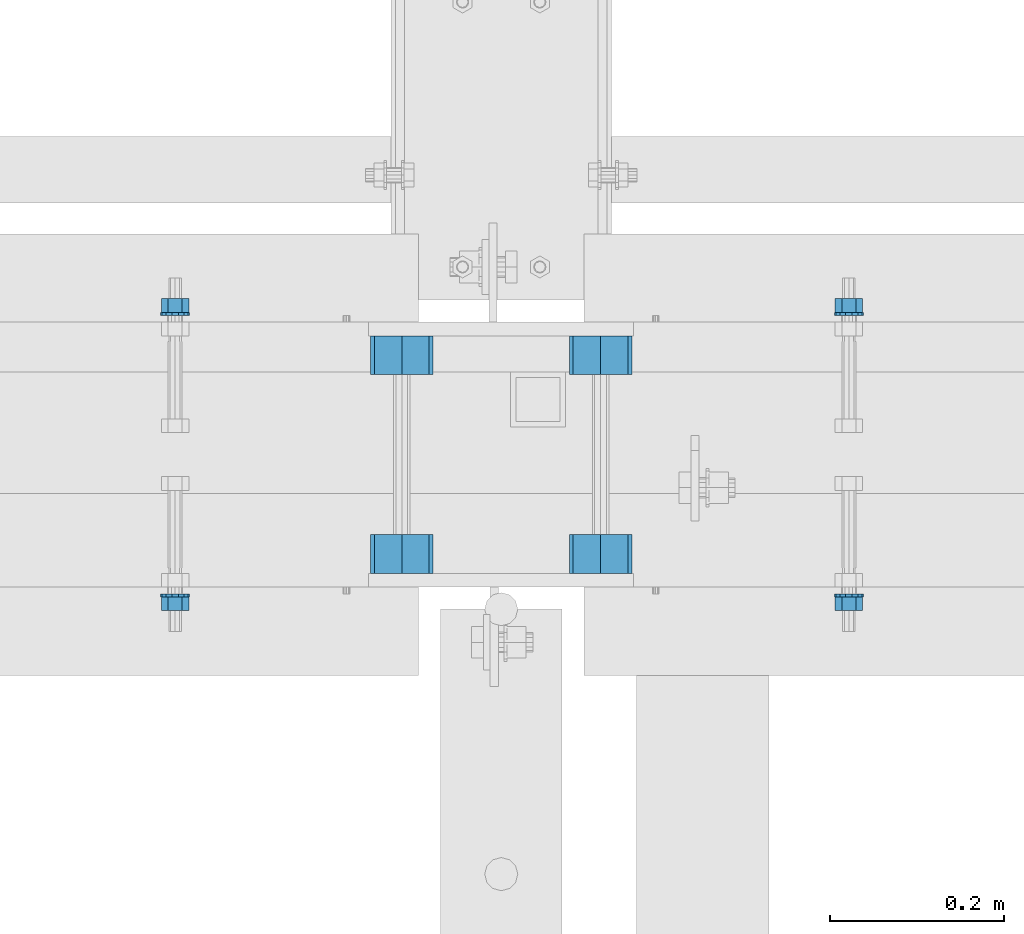
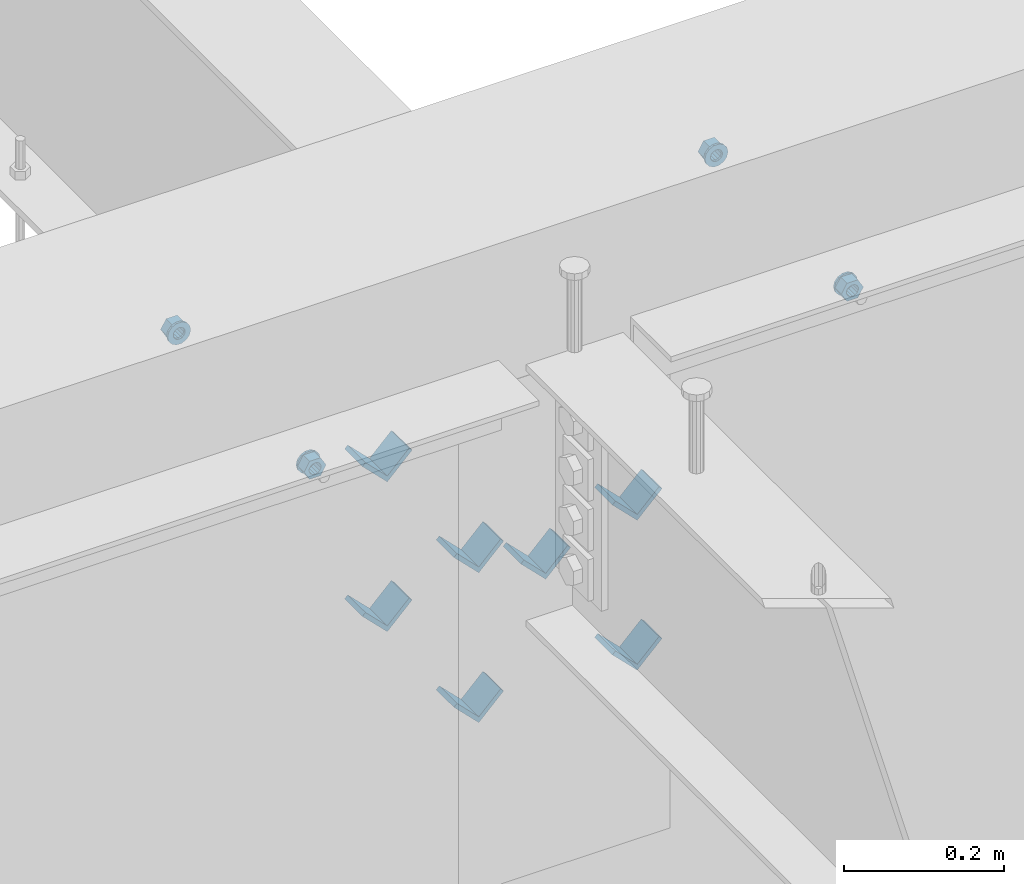
# One storey, part 609 of 975: 15 beams.
"""IFC2X3 building model written with IfcOpenShell, lengths in millimetres."""

from ifc_helpers import new_model, si_unit, frame, origin_with_axes, place, context, subcontext, project, spatial, faceted_brep, material, type_object, element, save


model = new_model("IFC2X3")

# Units and contexts
model_context = context("Model", 3, precision=1e-05, world=origin_with_axes())
body_context = subcontext(model_context, "Body", "Model", "MODEL_VIEW")
ifc_project = project(units=[si_unit("LENGTHUNIT", "METRE", prefix="MILLI"), si_unit("AREAUNIT", "SQUARE_METRE"), si_unit("VOLUMEUNIT", "CUBIC_METRE"), si_unit("MASSUNIT", "GRAM", prefix="KILO"), si_unit("TIMEUNIT", "SECOND"), si_unit("PLANEANGLEUNIT", "RADIAN"), si_unit("SOLIDANGLEUNIT", "STERADIAN"), si_unit("THERMODYNAMICTEMPERATUREUNIT", "DEGREE_CELSIUS"), si_unit("LUMINOUSINTENSITYUNIT", "LUMEN")], contexts=[model_context])

# Site, building, storey
site_placement = place(None, origin_with_axes())
site = spatial("IfcSite", under=ifc_project, at=site_placement, CompositionType="ELEMENT")
building_placement = place(site_placement, origin_with_axes())
building = spatial("IfcBuilding", under=site, at=building_placement, Name="Undefined", CompositionType="ELEMENT")
storey_placement = place(building_placement, origin_with_axes())
storey = spatial("IfcBuildingStorey", under=building, at=storey_placement, Name="Undefined", CompositionType="ELEMENT", Elevation=0.0)

# Beams
ifc_material = material(Name="STEEL/A36")
beam_type_1 = type_object("IfcBeamType", Name="L2X2X1/4", PredefinedType="NOTDEFINED")
for number, where, z_axis, x_axis, name in (
    (1, (8115.30041900943, 20459.6337290899, 3417.06996517217), (-0.707106781186557, 0.0, 0.707106781186538), (0.0, 1.0, 0.0), "ANGLE"),
    (2, (8343.90041900943, 20459.6337290899, 3417.06996517217), (-0.707106781186557, 0.0, 0.707106781186538), (0.0, 1.0, 0.0), "ANGLE"),
    (3, (8115.30041900943, 20688.3662709101, 3417.06996517217), (-0.707106781186557, 0.0, 0.707106781186538), (0.0, 1.0, 0.0), "ANGLE"),
    (4, (8343.90041900943, 20688.3662709101, 3417.06996517217), (-0.707106781186557, 0.0, 0.707106781186538), (0.0, 1.0, 0.0), "ANGLE"),
    (5, (8115.30041900943, 20459.6337290899, 3645.66996517217), (-0.707106781186557, 0.0, 0.707106781186538), (0.0, 1.0, 0.0), "ANGLE"),
    (6, (8343.90041900943, 20459.6337290899, 3645.66996517217), (-0.707106781186557, 0.0, 0.707106781186538), (0.0, 1.0, 0.0), "ANGLE"),
    (7, (8115.30041900943, 20688.3662709101, 3645.66996517217), (-0.707106781186557, 0.0, 0.707106781186538), (0.0, 1.0, 0.0), "ANGLE"),
):
    element("IfcBeam", number, at=place(storey_placement, frame(where, z_axis=z_axis, x_axis=x_axis)), inside=storey, type_object=beam_type_1, material=ifc_material, Name=name, ObjectType="L2X2X1/4", context=body_context, shape_type="Brep", body=[
        faceted_brep([(0.0, 25.3999999999724, -25.4000000000342), (0.0, 25.400000000016, 25.4000000000196), (44.4499999999971, 25.4000000000033, 25.4000000000051), (44.4499999999971, 25.4000000000033, -25.4000000000024), (3.27418092638254e-11, 19.0500000000002, 25.4000000000269), (44.4499999999971, 19.0500000000011, 25.400000000006), (-2.5465851649642e-11, 19.0500000000002, -19.0500000000211), (44.4499999999971, 19.0500000000011, -19.050000000002), (-2.5465851649642e-11, -25.3999999999996, -19.0500000000211), (44.4499999999971, -25.4000000000069, -19.0500000000038), (0.0, -25.400000000016, -25.4000000000196), (44.4499999999971, -25.4000000000069, -25.4000000000033)], [[[0, 1, 2, 3]], [[1, 4, 5, 2]], [[4, 6, 7, 5]], [[6, 8, 9, 7]], [[8, 10, 11, 9]], [[10, 0, 3, 11]], [[5, 7, 9, 11, 3, 2]], [[10, 8, 6, 4, 1, 0]]]),
    ])
beam_type_2 = type_object("IfcBeamType", Name="5/8_HEAVY_HEX_NUT", PredefinedType="NOTDEFINED")
beam_1_placement = place(storey_placement, frame((7854.4208401876, 20775.6125, 3886.2), z_axis=(0.0, 0.0, -1.0), x_axis=(0.0, -1.0, 0.0)))
element("IfcBeam", 8, at=beam_1_placement, inside=storey, type_object=beam_type_2, material=ifc_material, Name="NUT", ObjectType="5/8_HEAVY_HEX_NUT", context=body_context, shape_type="Brep", body=[
    faceted_brep([(-1.09139364212751e-11, -15.8800001144436, -2.72848410531878e-12), (1.45519152283669e-11, -7.94000005722046, -13.7500000000036), (15.8750000000146, -7.94000005722137, -13.7500000000045), (15.8749999999891, -15.8800001144446, -2.72848410531878e-12), (2.91038304567337e-11, 7.94000005722319, -13.7500000000027), (15.8750000000291, 7.94000005722319, -13.7500000000027), (2.18278728425503e-11, 15.8800001144436, 9.09494701772928e-13), (15.8750000000218, 15.8800001144427, 9.09494701772928e-13), (-7.27595761418343e-12, 7.94000005722046, 13.7500000000027), (15.8749999999927, 7.94000005722046, 13.7500000000027), (-2.18278728425503e-11, -7.94000005722228, 13.7500000000009), (15.8749999999782, -7.94000005722319, 13.7500000000009), (-7.27595761418343e-12, 0.0, 8.72999954223724), (0.0, 3.78780484388062, 7.86545780435881), (15.875, 3.78780484387971, 7.86545780435881), (15.8749999999927, -9.09494701772928e-13, 8.72999954223724), (7.27595761418343e-12, 6.82538848405238, 5.44306568481716), (15.8750000000073, 6.82538848405238, 5.44306568481716), (1.09139364212751e-11, 8.51112022706275, 1.94260765157742), (15.8750000000109, 8.51112022706093, 1.94260765157651), (1.45519152283669e-11, 8.51112022706184, -1.94260765157651), (15.8750000000146, 8.51112022706184, -1.94260765157651), (2.18278728425503e-11, 6.8253884840542, -5.44306568481716), (15.8750000000218, 6.82538848405238, -5.44306568481716), (1.81898940354586e-11, 3.78780484388153, -7.86545780435881), (15.8750000000182, 3.78780484388062, -7.86545780435881), (1.81898940354586e-11, 9.09494701772928e-13, -8.72999954223997), (15.8750000000182, 9.09494701772928e-13, -8.72999954223997), (1.09139364212751e-11, -3.78780484387971, -7.86545780436063), (15.8750000000109, -3.78780484388062, -7.86545780436063), (3.63797880709171e-12, -6.82538848405238, -5.44306568481807), (15.8750000000036, -6.82538848405329, -5.44306568481807), (0.0, -8.51112022706184, -1.94260765157833), (15.875, -8.51112022706184, -1.94260765157833), (-7.27595761418343e-12, -8.51112022706184, 1.9426076515756), (15.8749999999927, -8.51112022706275, 1.9426076515756), (-1.09139364212751e-11, -6.82538848405329, 5.44306568481534), (15.8749999999927, -6.8253884840542, 5.44306568481534), (-7.27595761418343e-12, -3.78780484388062, 7.8654578043579), (15.8749999999927, -3.78780484388153, 7.8654578043579)], [[[0, 1, 2, 3]], [[1, 4, 5, 2]], [[4, 6, 7, 5]], [[6, 8, 9, 7]], [[8, 10, 11, 9]], [[10, 0, 3, 11]], [[12, 13, 14, 15]], [[13, 16, 17, 14]], [[16, 18, 19, 17]], [[18, 20, 21, 19]], [[20, 22, 23, 21]], [[22, 24, 25, 23]], [[24, 26, 27, 25]], [[26, 28, 29, 27]], [[28, 30, 31, 29]], [[30, 32, 33, 31]], [[32, 34, 35, 33]], [[34, 36, 37, 35]], [[36, 38, 39, 37]], [[38, 12, 15, 39]], [[5, 7, 9, 11, 3, 2], [17, 19, 21, 23, 25, 27, 29, 31, 33, 35, 37, 39, 15, 14]], [[10, 8, 6, 4, 1, 0], [38, 36, 34, 32, 30, 28, 26, 24, 22, 20, 18, 16, 13, 12]]]),
])
beam_2_placement = place(storey_placement, frame((8629.6499755824, 20775.6125, 3886.2), z_axis=(0.0, 0.0, 1.0), x_axis=(0.0, -1.0, 0.0)))
element("IfcBeam", 9, at=beam_2_placement, inside=storey, type_object=beam_type_2, material=ifc_material, Name="NUT", ObjectType="5/8_HEAVY_HEX_NUT", context=body_context, shape_type="Brep", body=[
    faceted_brep([(-1.09139364212751e-11, -15.8800001144436, -2.72848410531878e-12), (1.45519152283669e-11, -7.94000005722046, -13.7500000000036), (15.8750000000146, -7.94000005722137, -13.7500000000045), (15.8749999999891, -15.8800001144446, -2.72848410531878e-12), (2.91038304567337e-11, 7.94000005722319, -13.7500000000027), (15.8750000000291, 7.94000005722319, -13.7500000000027), (2.18278728425503e-11, 15.8800001144436, 9.09494701772928e-13), (15.8750000000218, 15.8800001144427, 9.09494701772928e-13), (-7.27595761418343e-12, 7.94000005722046, 13.7500000000027), (15.8749999999927, 7.94000005722046, 13.7500000000027), (-2.18278728425503e-11, -7.94000005722228, 13.7500000000009), (15.8749999999782, -7.94000005722319, 13.7500000000009), (-7.27595761418343e-12, 0.0, 8.72999954223724), (0.0, 3.78780484388062, 7.86545780435881), (15.875, 3.78780484387971, 7.86545780435881), (15.8749999999927, -9.09494701772928e-13, 8.72999954223724), (7.27595761418343e-12, 6.82538848405238, 5.44306568481716), (15.8750000000073, 6.82538848405238, 5.44306568481716), (1.09139364212751e-11, 8.51112022706275, 1.94260765157742), (15.8750000000109, 8.51112022706093, 1.94260765157651), (1.45519152283669e-11, 8.51112022706184, -1.94260765157651), (15.8750000000146, 8.51112022706184, -1.94260765157651), (2.18278728425503e-11, 6.8253884840542, -5.44306568481716), (15.8750000000218, 6.82538848405238, -5.44306568481716), (1.81898940354586e-11, 3.78780484388153, -7.86545780435881), (15.8750000000182, 3.78780484388062, -7.86545780435881), (1.81898940354586e-11, 9.09494701772928e-13, -8.72999954223997), (15.8750000000182, 9.09494701772928e-13, -8.72999954223997), (1.09139364212751e-11, -3.78780484387971, -7.86545780436063), (15.8750000000109, -3.78780484388062, -7.86545780436063), (3.63797880709171e-12, -6.82538848405238, -5.44306568481807), (15.8750000000036, -6.82538848405329, -5.44306568481807), (0.0, -8.51112022706184, -1.94260765157833), (15.875, -8.51112022706184, -1.94260765157833), (-7.27595761418343e-12, -8.51112022706184, 1.9426076515756), (15.8749999999927, -8.51112022706275, 1.9426076515756), (-1.09139364212751e-11, -6.82538848405329, 5.44306568481534), (15.8749999999927, -6.8253884840542, 5.44306568481534), (-7.27595761418343e-12, -3.78780484388062, 7.8654578043579), (15.8749999999927, -3.78780484388153, 7.8654578043579)], [[[0, 1, 2, 3]], [[1, 4, 5, 2]], [[4, 6, 7, 5]], [[6, 8, 9, 7]], [[8, 10, 11, 9]], [[10, 0, 3, 11]], [[12, 13, 14, 15]], [[13, 16, 17, 14]], [[16, 18, 19, 17]], [[18, 20, 21, 19]], [[20, 22, 23, 21]], [[22, 24, 25, 23]], [[24, 26, 27, 25]], [[26, 28, 29, 27]], [[28, 30, 31, 29]], [[30, 32, 33, 31]], [[32, 34, 35, 33]], [[34, 36, 37, 35]], [[36, 38, 39, 37]], [[38, 12, 15, 39]], [[5, 7, 9, 11, 3, 2], [17, 19, 21, 23, 25, 27, 29, 31, 33, 35, 37, 39, 15, 14]], [[10, 8, 6, 4, 1, 0], [38, 36, 34, 32, 30, 28, 26, 24, 22, 20, 18, 16, 13, 12]]]),
])
beam_3_placement = place(storey_placement, frame((7854.4208401876, 20416.8375, 3886.2), z_axis=(0.0, 0.0, 1.0), x_axis=(0.0, 1.0, 0.0)))
element("IfcBeam", 10, at=beam_3_placement, inside=storey, type_object=beam_type_2, material=ifc_material, Name="NUT", ObjectType="5/8_HEAVY_HEX_NUT", context=body_context, shape_type="Brep", body=[
    faceted_brep([(-1.09139364212751e-11, -15.8800001144436, -2.72848410531878e-12), (1.45519152283669e-11, -7.94000005722046, -13.7500000000036), (15.8750000000146, -7.94000005722137, -13.7500000000045), (15.8749999999891, -15.8800001144446, -2.72848410531878e-12), (2.91038304567337e-11, 7.94000005722319, -13.7500000000027), (15.8750000000291, 7.94000005722319, -13.7500000000027), (2.18278728425503e-11, 15.8800001144436, 9.09494701772928e-13), (15.8750000000218, 15.8800001144427, 9.09494701772928e-13), (-7.27595761418343e-12, 7.94000005722046, 13.7500000000027), (15.8749999999927, 7.94000005722046, 13.7500000000027), (-2.18278728425503e-11, -7.94000005722228, 13.7500000000009), (15.8749999999782, -7.94000005722319, 13.7500000000009), (-7.27595761418343e-12, 0.0, 8.72999954223724), (0.0, 3.78780484388062, 7.86545780435881), (15.875, 3.78780484387971, 7.86545780435881), (15.8749999999927, -9.09494701772928e-13, 8.72999954223724), (7.27595761418343e-12, 6.82538848405238, 5.44306568481716), (15.8750000000073, 6.82538848405238, 5.44306568481716), (1.09139364212751e-11, 8.51112022706275, 1.94260765157742), (15.8750000000109, 8.51112022706093, 1.94260765157651), (1.45519152283669e-11, 8.51112022706184, -1.94260765157651), (15.8750000000146, 8.51112022706184, -1.94260765157651), (2.18278728425503e-11, 6.8253884840542, -5.44306568481716), (15.8750000000218, 6.82538848405238, -5.44306568481716), (1.81898940354586e-11, 3.78780484388153, -7.86545780435881), (15.8750000000182, 3.78780484388062, -7.86545780435881), (1.81898940354586e-11, 9.09494701772928e-13, -8.72999954223997), (15.8750000000182, 9.09494701772928e-13, -8.72999954223997), (1.09139364212751e-11, -3.78780484387971, -7.86545780436063), (15.8750000000109, -3.78780484388062, -7.86545780436063), (3.63797880709171e-12, -6.82538848405238, -5.44306568481807), (15.8750000000036, -6.82538848405329, -5.44306568481807), (0.0, -8.51112022706184, -1.94260765157833), (15.875, -8.51112022706184, -1.94260765157833), (-7.27595761418343e-12, -8.51112022706184, 1.9426076515756), (15.8749999999927, -8.51112022706275, 1.9426076515756), (-1.09139364212751e-11, -6.82538848405329, 5.44306568481534), (15.8749999999927, -6.8253884840542, 5.44306568481534), (-7.27595761418343e-12, -3.78780484388062, 7.8654578043579), (15.8749999999927, -3.78780484388153, 7.8654578043579)], [[[0, 1, 2, 3]], [[1, 4, 5, 2]], [[4, 6, 7, 5]], [[6, 8, 9, 7]], [[8, 10, 11, 9]], [[10, 0, 3, 11]], [[12, 13, 14, 15]], [[13, 16, 17, 14]], [[16, 18, 19, 17]], [[18, 20, 21, 19]], [[20, 22, 23, 21]], [[22, 24, 25, 23]], [[24, 26, 27, 25]], [[26, 28, 29, 27]], [[28, 30, 31, 29]], [[30, 32, 33, 31]], [[32, 34, 35, 33]], [[34, 36, 37, 35]], [[36, 38, 39, 37]], [[38, 12, 15, 39]], [[5, 7, 9, 11, 3, 2], [17, 19, 21, 23, 25, 27, 29, 31, 33, 35, 37, 39, 15, 14]], [[10, 8, 6, 4, 1, 0], [38, 36, 34, 32, 30, 28, 26, 24, 22, 20, 18, 16, 13, 12]]]),
])
beam_4_placement = place(storey_placement, frame((8629.6499755824, 20416.8375, 3886.2), z_axis=(0.0, 0.0, -1.0), x_axis=(0.0, 1.0, 0.0)))
element("IfcBeam", 11, at=beam_4_placement, inside=storey, type_object=beam_type_2, material=ifc_material, Name="NUT", ObjectType="5/8_HEAVY_HEX_NUT", context=body_context, shape_type="Brep", body=[
    faceted_brep([(-1.09139364212751e-11, -15.8800001144436, -2.72848410531878e-12), (1.45519152283669e-11, -7.94000005722046, -13.7500000000036), (15.8750000000146, -7.94000005722137, -13.7500000000045), (15.8749999999891, -15.8800001144446, -2.72848410531878e-12), (2.91038304567337e-11, 7.94000005722319, -13.7500000000027), (15.8750000000291, 7.94000005722319, -13.7500000000027), (2.18278728425503e-11, 15.8800001144436, 9.09494701772928e-13), (15.8750000000218, 15.8800001144427, 9.09494701772928e-13), (-7.27595761418343e-12, 7.94000005722046, 13.7500000000027), (15.8749999999927, 7.94000005722046, 13.7500000000027), (-2.18278728425503e-11, -7.94000005722228, 13.7500000000009), (15.8749999999782, -7.94000005722319, 13.7500000000009), (-7.27595761418343e-12, 0.0, 8.72999954223724), (0.0, 3.78780484388062, 7.86545780435881), (15.875, 3.78780484387971, 7.86545780435881), (15.8749999999927, -9.09494701772928e-13, 8.72999954223724), (7.27595761418343e-12, 6.82538848405238, 5.44306568481716), (15.8750000000073, 6.82538848405238, 5.44306568481716), (1.09139364212751e-11, 8.51112022706275, 1.94260765157742), (15.8750000000109, 8.51112022706093, 1.94260765157651), (1.45519152283669e-11, 8.51112022706184, -1.94260765157651), (15.8750000000146, 8.51112022706184, -1.94260765157651), (2.18278728425503e-11, 6.8253884840542, -5.44306568481716), (15.8750000000218, 6.82538848405238, -5.44306568481716), (1.81898940354586e-11, 3.78780484388153, -7.86545780435881), (15.8750000000182, 3.78780484388062, -7.86545780435881), (1.81898940354586e-11, 9.09494701772928e-13, -8.72999954223997), (15.8750000000182, 9.09494701772928e-13, -8.72999954223997), (1.09139364212751e-11, -3.78780484387971, -7.86545780436063), (15.8750000000109, -3.78780484388062, -7.86545780436063), (3.63797880709171e-12, -6.82538848405238, -5.44306568481807), (15.8750000000036, -6.82538848405329, -5.44306568481807), (0.0, -8.51112022706184, -1.94260765157833), (15.875, -8.51112022706184, -1.94260765157833), (-7.27595761418343e-12, -8.51112022706184, 1.9426076515756), (15.8749999999927, -8.51112022706275, 1.9426076515756), (-1.09139364212751e-11, -6.82538848405329, 5.44306568481534), (15.8749999999927, -6.8253884840542, 5.44306568481534), (-7.27595761418343e-12, -3.78780484388062, 7.8654578043579), (15.8749999999927, -3.78780484388153, 7.8654578043579)], [[[0, 1, 2, 3]], [[1, 4, 5, 2]], [[4, 6, 7, 5]], [[6, 8, 9, 7]], [[8, 10, 11, 9]], [[10, 0, 3, 11]], [[12, 13, 14, 15]], [[13, 16, 17, 14]], [[16, 18, 19, 17]], [[18, 20, 21, 19]], [[20, 22, 23, 21]], [[22, 24, 25, 23]], [[24, 26, 27, 25]], [[26, 28, 29, 27]], [[28, 30, 31, 29]], [[30, 32, 33, 31]], [[32, 34, 35, 33]], [[34, 36, 37, 35]], [[36, 38, 39, 37]], [[38, 12, 15, 39]], [[5, 7, 9, 11, 3, 2], [17, 19, 21, 23, 25, 27, 29, 31, 33, 35, 37, 39, 15, 14]], [[10, 8, 6, 4, 1, 0], [38, 36, 34, 32, 30, 28, 26, 24, 22, 20, 18, 16, 13, 12]]]),
])
beam_type_3 = type_object("IfcBeamType", Name="5/8_WASHER", PredefinedType="NOTDEFINED")
beam_5_placement = place(storey_placement, frame((7854.42084018762, 20759.7375, 3886.2), z_axis=(0.0, 0.0, -1.0), x_axis=(0.0, -1.0, 0.0)))
element("IfcBeam", 12, at=beam_5_placement, inside=storey, type_object=beam_type_3, material=ifc_material, Name="WASHER", ObjectType="5/8_WASHER", context=body_context, shape_type="Brep", body=[
    faceted_brep([(1.09139364212751e-11, -16.670000076293, -2.72848410531878e-12), (2.18278728425503e-11, -15.0191510966704, -7.23284196419536), (3.1750000000211, -15.0191510966711, -7.23284196419627), (3.17500000001019, -16.6700000762937, -1.81898940354586e-12), (2.91038304567337e-11, -10.3935750445523, -13.0331308723944), (3.17500000002838, -10.3935750445526, -13.0331308723953), (2.91038304567337e-11, -3.70942398602756, -16.2520483704566), (3.17500000002838, -3.70942398602779, -16.2520483704566), (2.5465851649642e-11, 3.70942398602961, -16.2520483704557), (3.17500000002474, 3.70942398602961, -16.2520483704566), (1.45519152283669e-11, 10.3935750445542, -13.0331308723935), (3.17500000001382, 10.3935750445537, -13.0331308723944), (0.0, 15.0191510966717, -7.23284196419354), (3.17499999999927, 15.0191510966713, -7.23284196419354), (-7.27595761418343e-12, 16.6700000762933, 0.0), (3.174999999992, 16.6700000762928, -9.09494701772928e-13), (-1.81898940354586e-11, 15.0191510966706, 7.23284196419354), (3.17499999998108, 15.0191510966704, 7.23284196419354), (-2.5465851649642e-11, 10.3935750445519, 13.0331308723926), (3.17499999997381, 10.3935750445517, 13.0331308723926), (-2.5465851649642e-11, 3.70942398602733, 16.2520483704538), (3.17499999997381, 3.7094239860271, 16.2520483704529), (-2.18278728425503e-11, -3.70942398602983, 16.2520483704529), (3.17499999997744, -3.70942398603006, 16.2520483704538), (-1.09139364212751e-11, -10.3935750445542, 13.0331308723908), (3.17499999998836, -10.3935750445544, 13.0331308723908), (0.0, -15.0191510966717, 7.23284196419172), (3.17499999999927, -15.019151096672, 7.23284196419081), (-7.27595761418343e-12, 0.0, 8.72999954223724), (0.0, 3.78780484388062, 7.86545780435881), (3.17499999998472, 3.78780484387903, 7.86545780435699), (3.17499999998836, -9.09494701772928e-13, 8.72999954223542), (7.27595761418343e-12, 6.82538848405238, 5.44306568481716), (3.17499999998836, 6.82538848405102, 5.44306568481534), (1.09139364212751e-11, 8.51112022706275, 1.94260765157742), (3.174999999992, 8.51112022705979, 1.94260765157651), (1.45519152283669e-11, 8.51112022706184, -1.94260765157651), (3.17499999999563, 8.51112022706025, -1.94260765157742), (2.18278728425503e-11, 6.8253884840542, -5.44306568481716), (3.17500000000655, 6.8253884840517, -5.44306568481807), (1.81898940354586e-11, 3.78780484388153, -7.86545780435881), (3.17500000001019, 3.78780484388017, -7.86545780435972), (1.81898940354586e-11, 9.09494701772928e-13, -8.72999954223997), (3.17500000001382, 6.82121026329696e-13, -8.72999954223997), (1.09139364212751e-11, -3.78780484387971, -7.86545780436063), (3.17500000001382, -3.78780484387994, -7.86545780436063), (3.63797880709171e-12, -6.82538848405238, -5.44306568481807), (3.17500000001019, -6.82538848405147, -5.44306568481898), (0.0, -8.51112022706184, -1.94260765157833), (3.17500000001019, -8.5111202270607, -1.94260765157924), (-7.27595761418343e-12, -8.51112022706184, 1.9426076515756), (3.17500000000291, -8.51112022706093, 1.94260765157469), (-1.09139364212751e-11, -6.82538848405329, 5.44306568481534), (3.17499999999563, -6.82538848405238, 5.44306568481534), (-7.27595761418343e-12, -3.78780484388062, 7.8654578043579), (3.174999999992, -3.78780484388085, 7.86545780435699)], [[[0, 1, 2, 3]], [[1, 4, 5, 2]], [[4, 6, 7, 5]], [[6, 8, 9, 7]], [[8, 10, 11, 9]], [[10, 12, 13, 11]], [[12, 14, 15, 13]], [[14, 16, 17, 15]], [[16, 18, 19, 17]], [[18, 20, 21, 19]], [[20, 22, 23, 21]], [[22, 24, 25, 23]], [[24, 26, 27, 25]], [[26, 0, 3, 27]], [[28, 29, 30, 31]], [[29, 32, 33, 30]], [[32, 34, 35, 33]], [[34, 36, 37, 35]], [[36, 38, 39, 37]], [[38, 40, 41, 39]], [[40, 42, 43, 41]], [[42, 44, 45, 43]], [[44, 46, 47, 45]], [[46, 48, 49, 47]], [[48, 50, 51, 49]], [[50, 52, 53, 51]], [[52, 54, 55, 53]], [[54, 28, 31, 55]], [[5, 7, 9, 11, 13, 15, 17, 19, 21, 23, 25, 27, 3, 2], [33, 35, 37, 39, 41, 43, 45, 47, 49, 51, 53, 55, 31, 30]], [[26, 24, 22, 20, 18, 16, 14, 12, 10, 8, 6, 4, 1, 0], [54, 52, 50, 48, 46, 44, 42, 40, 38, 36, 34, 32, 29, 28]]]),
])
beam_6_placement = place(storey_placement, frame((8629.64997558244, 20759.7375, 3886.2), z_axis=(0.0, 0.0, 1.0), x_axis=(0.0, -1.0, 0.0)))
element("IfcBeam", 13, at=beam_6_placement, inside=storey, type_object=beam_type_3, material=ifc_material, Name="WASHER", ObjectType="5/8_WASHER", context=body_context, shape_type="Brep", body=[
    faceted_brep([(1.09139364212751e-11, -16.670000076293, -2.72848410531878e-12), (2.18278728425503e-11, -15.0191510966704, -7.23284196419536), (3.1750000000211, -15.0191510966711, -7.23284196419627), (3.17500000001019, -16.6700000762937, -1.81898940354586e-12), (2.91038304567337e-11, -10.3935750445523, -13.0331308723944), (3.17500000002838, -10.3935750445526, -13.0331308723953), (2.91038304567337e-11, -3.70942398602756, -16.2520483704566), (3.17500000002838, -3.70942398602779, -16.2520483704566), (2.5465851649642e-11, 3.70942398602961, -16.2520483704557), (3.17500000002474, 3.70942398602961, -16.2520483704566), (1.45519152283669e-11, 10.3935750445542, -13.0331308723935), (3.17500000001382, 10.3935750445537, -13.0331308723944), (0.0, 15.0191510966717, -7.23284196419354), (3.17499999999927, 15.0191510966713, -7.23284196419354), (-7.27595761418343e-12, 16.6700000762933, 0.0), (3.174999999992, 16.6700000762928, -9.09494701772928e-13), (-1.81898940354586e-11, 15.0191510966706, 7.23284196419354), (3.17499999998108, 15.0191510966704, 7.23284196419354), (-2.5465851649642e-11, 10.3935750445519, 13.0331308723926), (3.17499999997381, 10.3935750445517, 13.0331308723926), (-2.5465851649642e-11, 3.70942398602733, 16.2520483704538), (3.17499999997381, 3.7094239860271, 16.2520483704529), (-2.18278728425503e-11, -3.70942398602983, 16.2520483704529), (3.17499999997744, -3.70942398603006, 16.2520483704538), (-1.09139364212751e-11, -10.3935750445542, 13.0331308723908), (3.17499999998836, -10.3935750445544, 13.0331308723908), (0.0, -15.0191510966717, 7.23284196419172), (3.17499999999927, -15.019151096672, 7.23284196419081), (-7.27595761418343e-12, 0.0, 8.72999954223724), (0.0, 3.78780484388062, 7.86545780435881), (3.17499999998472, 3.78780484387903, 7.86545780435699), (3.17499999998836, -9.09494701772928e-13, 8.72999954223542), (7.27595761418343e-12, 6.82538848405238, 5.44306568481716), (3.17499999998836, 6.82538848405102, 5.44306568481534), (1.09139364212751e-11, 8.51112022706275, 1.94260765157742), (3.174999999992, 8.51112022705979, 1.94260765157651), (1.45519152283669e-11, 8.51112022706184, -1.94260765157651), (3.17499999999563, 8.51112022706025, -1.94260765157742), (2.18278728425503e-11, 6.8253884840542, -5.44306568481716), (3.17500000000655, 6.8253884840517, -5.44306568481807), (1.81898940354586e-11, 3.78780484388153, -7.86545780435881), (3.17500000001019, 3.78780484388017, -7.86545780435972), (1.81898940354586e-11, 9.09494701772928e-13, -8.72999954223997), (3.17500000001382, 6.82121026329696e-13, -8.72999954223997), (1.09139364212751e-11, -3.78780484387971, -7.86545780436063), (3.17500000001382, -3.78780484387994, -7.86545780436063), (3.63797880709171e-12, -6.82538848405238, -5.44306568481807), (3.17500000001019, -6.82538848405147, -5.44306568481898), (0.0, -8.51112022706184, -1.94260765157833), (3.17500000001019, -8.5111202270607, -1.94260765157924), (-7.27595761418343e-12, -8.51112022706184, 1.9426076515756), (3.17500000000291, -8.51112022706093, 1.94260765157469), (-1.09139364212751e-11, -6.82538848405329, 5.44306568481534), (3.17499999999563, -6.82538848405238, 5.44306568481534), (-7.27595761418343e-12, -3.78780484388062, 7.8654578043579), (3.174999999992, -3.78780484388085, 7.86545780435699)], [[[0, 1, 2, 3]], [[1, 4, 5, 2]], [[4, 6, 7, 5]], [[6, 8, 9, 7]], [[8, 10, 11, 9]], [[10, 12, 13, 11]], [[12, 14, 15, 13]], [[14, 16, 17, 15]], [[16, 18, 19, 17]], [[18, 20, 21, 19]], [[20, 22, 23, 21]], [[22, 24, 25, 23]], [[24, 26, 27, 25]], [[26, 0, 3, 27]], [[28, 29, 30, 31]], [[29, 32, 33, 30]], [[32, 34, 35, 33]], [[34, 36, 37, 35]], [[36, 38, 39, 37]], [[38, 40, 41, 39]], [[40, 42, 43, 41]], [[42, 44, 45, 43]], [[44, 46, 47, 45]], [[46, 48, 49, 47]], [[48, 50, 51, 49]], [[50, 52, 53, 51]], [[52, 54, 55, 53]], [[54, 28, 31, 55]], [[5, 7, 9, 11, 13, 15, 17, 19, 21, 23, 25, 27, 3, 2], [33, 35, 37, 39, 41, 43, 45, 47, 49, 51, 53, 55, 31, 30]], [[26, 24, 22, 20, 18, 16, 14, 12, 10, 8, 6, 4, 1, 0], [54, 52, 50, 48, 46, 44, 42, 40, 38, 36, 34, 32, 29, 28]]]),
])
beam_7_placement = place(storey_placement, frame((7854.42084018762, 20432.7125, 3886.2), z_axis=(0.0, 0.0, 1.0), x_axis=(0.0, 1.0, 0.0)))
element("IfcBeam", 14, at=beam_7_placement, inside=storey, type_object=beam_type_3, material=ifc_material, Name="WASHER", ObjectType="5/8_WASHER", context=body_context, shape_type="Brep", body=[
    faceted_brep([(1.09139364212751e-11, -16.670000076293, -2.72848410531878e-12), (2.18278728425503e-11, -15.0191510966704, -7.23284196419536), (3.1750000000211, -15.0191510966711, -7.23284196419627), (3.17500000001019, -16.6700000762937, -1.81898940354586e-12), (2.91038304567337e-11, -10.3935750445523, -13.0331308723944), (3.17500000002838, -10.3935750445526, -13.0331308723953), (2.91038304567337e-11, -3.70942398602756, -16.2520483704566), (3.17500000002838, -3.70942398602779, -16.2520483704566), (2.5465851649642e-11, 3.70942398602961, -16.2520483704557), (3.17500000002474, 3.70942398602961, -16.2520483704566), (1.45519152283669e-11, 10.3935750445542, -13.0331308723935), (3.17500000001382, 10.3935750445537, -13.0331308723944), (0.0, 15.0191510966717, -7.23284196419354), (3.17499999999927, 15.0191510966713, -7.23284196419354), (-7.27595761418343e-12, 16.6700000762933, 0.0), (3.174999999992, 16.6700000762928, -9.09494701772928e-13), (-1.81898940354586e-11, 15.0191510966706, 7.23284196419354), (3.17499999998108, 15.0191510966704, 7.23284196419354), (-2.5465851649642e-11, 10.3935750445519, 13.0331308723926), (3.17499999997381, 10.3935750445517, 13.0331308723926), (-2.5465851649642e-11, 3.70942398602733, 16.2520483704538), (3.17499999997381, 3.7094239860271, 16.2520483704529), (-2.18278728425503e-11, -3.70942398602983, 16.2520483704529), (3.17499999997744, -3.70942398603006, 16.2520483704538), (-1.09139364212751e-11, -10.3935750445542, 13.0331308723908), (3.17499999998836, -10.3935750445544, 13.0331308723908), (0.0, -15.0191510966717, 7.23284196419172), (3.17499999999927, -15.019151096672, 7.23284196419081), (-7.27595761418343e-12, 0.0, 8.72999954223724), (0.0, 3.78780484388062, 7.86545780435881), (3.17499999998472, 3.78780484387903, 7.86545780435699), (3.17499999998836, -9.09494701772928e-13, 8.72999954223542), (7.27595761418343e-12, 6.82538848405238, 5.44306568481716), (3.17499999998836, 6.82538848405102, 5.44306568481534), (1.09139364212751e-11, 8.51112022706275, 1.94260765157742), (3.174999999992, 8.51112022705979, 1.94260765157651), (1.45519152283669e-11, 8.51112022706184, -1.94260765157651), (3.17499999999563, 8.51112022706025, -1.94260765157742), (2.18278728425503e-11, 6.8253884840542, -5.44306568481716), (3.17500000000655, 6.8253884840517, -5.44306568481807), (1.81898940354586e-11, 3.78780484388153, -7.86545780435881), (3.17500000001019, 3.78780484388017, -7.86545780435972), (1.81898940354586e-11, 9.09494701772928e-13, -8.72999954223997), (3.17500000001382, 6.82121026329696e-13, -8.72999954223997), (1.09139364212751e-11, -3.78780484387971, -7.86545780436063), (3.17500000001382, -3.78780484387994, -7.86545780436063), (3.63797880709171e-12, -6.82538848405238, -5.44306568481807), (3.17500000001019, -6.82538848405147, -5.44306568481898), (0.0, -8.51112022706184, -1.94260765157833), (3.17500000001019, -8.5111202270607, -1.94260765157924), (-7.27595761418343e-12, -8.51112022706184, 1.9426076515756), (3.17500000000291, -8.51112022706093, 1.94260765157469), (-1.09139364212751e-11, -6.82538848405329, 5.44306568481534), (3.17499999999563, -6.82538848405238, 5.44306568481534), (-7.27595761418343e-12, -3.78780484388062, 7.8654578043579), (3.174999999992, -3.78780484388085, 7.86545780435699)], [[[0, 1, 2, 3]], [[1, 4, 5, 2]], [[4, 6, 7, 5]], [[6, 8, 9, 7]], [[8, 10, 11, 9]], [[10, 12, 13, 11]], [[12, 14, 15, 13]], [[14, 16, 17, 15]], [[16, 18, 19, 17]], [[18, 20, 21, 19]], [[20, 22, 23, 21]], [[22, 24, 25, 23]], [[24, 26, 27, 25]], [[26, 0, 3, 27]], [[28, 29, 30, 31]], [[29, 32, 33, 30]], [[32, 34, 35, 33]], [[34, 36, 37, 35]], [[36, 38, 39, 37]], [[38, 40, 41, 39]], [[40, 42, 43, 41]], [[42, 44, 45, 43]], [[44, 46, 47, 45]], [[46, 48, 49, 47]], [[48, 50, 51, 49]], [[50, 52, 53, 51]], [[52, 54, 55, 53]], [[54, 28, 31, 55]], [[5, 7, 9, 11, 13, 15, 17, 19, 21, 23, 25, 27, 3, 2], [33, 35, 37, 39, 41, 43, 45, 47, 49, 51, 53, 55, 31, 30]], [[26, 24, 22, 20, 18, 16, 14, 12, 10, 8, 6, 4, 1, 0], [54, 52, 50, 48, 46, 44, 42, 40, 38, 36, 34, 32, 29, 28]]]),
])
beam_8_placement = place(storey_placement, frame((8629.64997558244, 20432.7125, 3886.2), z_axis=(0.0, 0.0, -1.0), x_axis=(0.0, 1.0, 0.0)))
element("IfcBeam", 15, at=beam_8_placement, inside=storey, type_object=beam_type_3, material=ifc_material, Name="WASHER", ObjectType="5/8_WASHER", context=body_context, shape_type="Brep", body=[
    faceted_brep([(1.09139364212751e-11, -16.670000076293, -2.72848410531878e-12), (2.18278728425503e-11, -15.0191510966704, -7.23284196419536), (3.1750000000211, -15.0191510966711, -7.23284196419627), (3.17500000001019, -16.6700000762937, -1.81898940354586e-12), (2.91038304567337e-11, -10.3935750445523, -13.0331308723944), (3.17500000002838, -10.3935750445526, -13.0331308723953), (2.91038304567337e-11, -3.70942398602756, -16.2520483704566), (3.17500000002838, -3.70942398602779, -16.2520483704566), (2.5465851649642e-11, 3.70942398602961, -16.2520483704557), (3.17500000002474, 3.70942398602961, -16.2520483704566), (1.45519152283669e-11, 10.3935750445542, -13.0331308723935), (3.17500000001382, 10.3935750445537, -13.0331308723944), (0.0, 15.0191510966717, -7.23284196419354), (3.17499999999927, 15.0191510966713, -7.23284196419354), (-7.27595761418343e-12, 16.6700000762933, 0.0), (3.174999999992, 16.6700000762928, -9.09494701772928e-13), (-1.81898940354586e-11, 15.0191510966706, 7.23284196419354), (3.17499999998108, 15.0191510966704, 7.23284196419354), (-2.5465851649642e-11, 10.3935750445519, 13.0331308723926), (3.17499999997381, 10.3935750445517, 13.0331308723926), (-2.5465851649642e-11, 3.70942398602733, 16.2520483704538), (3.17499999997381, 3.7094239860271, 16.2520483704529), (-2.18278728425503e-11, -3.70942398602983, 16.2520483704529), (3.17499999997744, -3.70942398603006, 16.2520483704538), (-1.09139364212751e-11, -10.3935750445542, 13.0331308723908), (3.17499999998836, -10.3935750445544, 13.0331308723908), (0.0, -15.0191510966717, 7.23284196419172), (3.17499999999927, -15.019151096672, 7.23284196419081), (-7.27595761418343e-12, 0.0, 8.72999954223724), (0.0, 3.78780484388062, 7.86545780435881), (3.17499999998472, 3.78780484387903, 7.86545780435699), (3.17499999998836, -9.09494701772928e-13, 8.72999954223542), (7.27595761418343e-12, 6.82538848405238, 5.44306568481716), (3.17499999998836, 6.82538848405102, 5.44306568481534), (1.09139364212751e-11, 8.51112022706275, 1.94260765157742), (3.174999999992, 8.51112022705979, 1.94260765157651), (1.45519152283669e-11, 8.51112022706184, -1.94260765157651), (3.17499999999563, 8.51112022706025, -1.94260765157742), (2.18278728425503e-11, 6.8253884840542, -5.44306568481716), (3.17500000000655, 6.8253884840517, -5.44306568481807), (1.81898940354586e-11, 3.78780484388153, -7.86545780435881), (3.17500000001019, 3.78780484388017, -7.86545780435972), (1.81898940354586e-11, 9.09494701772928e-13, -8.72999954223997), (3.17500000001382, 6.82121026329696e-13, -8.72999954223997), (1.09139364212751e-11, -3.78780484387971, -7.86545780436063), (3.17500000001382, -3.78780484387994, -7.86545780436063), (3.63797880709171e-12, -6.82538848405238, -5.44306568481807), (3.17500000001019, -6.82538848405147, -5.44306568481898), (0.0, -8.51112022706184, -1.94260765157833), (3.17500000001019, -8.5111202270607, -1.94260765157924), (-7.27595761418343e-12, -8.51112022706184, 1.9426076515756), (3.17500000000291, -8.51112022706093, 1.94260765157469), (-1.09139364212751e-11, -6.82538848405329, 5.44306568481534), (3.17499999999563, -6.82538848405238, 5.44306568481534), (-7.27595761418343e-12, -3.78780484388062, 7.8654578043579), (3.174999999992, -3.78780484388085, 7.86545780435699)], [[[0, 1, 2, 3]], [[1, 4, 5, 2]], [[4, 6, 7, 5]], [[6, 8, 9, 7]], [[8, 10, 11, 9]], [[10, 12, 13, 11]], [[12, 14, 15, 13]], [[14, 16, 17, 15]], [[16, 18, 19, 17]], [[18, 20, 21, 19]], [[20, 22, 23, 21]], [[22, 24, 25, 23]], [[24, 26, 27, 25]], [[26, 0, 3, 27]], [[28, 29, 30, 31]], [[29, 32, 33, 30]], [[32, 34, 35, 33]], [[34, 36, 37, 35]], [[36, 38, 39, 37]], [[38, 40, 41, 39]], [[40, 42, 43, 41]], [[42, 44, 45, 43]], [[44, 46, 47, 45]], [[46, 48, 49, 47]], [[48, 50, 51, 49]], [[50, 52, 53, 51]], [[52, 54, 55, 53]], [[54, 28, 31, 55]], [[5, 7, 9, 11, 13, 15, 17, 19, 21, 23, 25, 27, 3, 2], [33, 35, 37, 39, 41, 43, 45, 47, 49, 51, 53, 55, 31, 30]], [[26, 24, 22, 20, 18, 16, 14, 12, 10, 8, 6, 4, 1, 0], [54, 52, 50, 48, 46, 44, 42, 40, 38, 36, 34, 32, 29, 28]]]),
])

save(model, "model.ifc")
